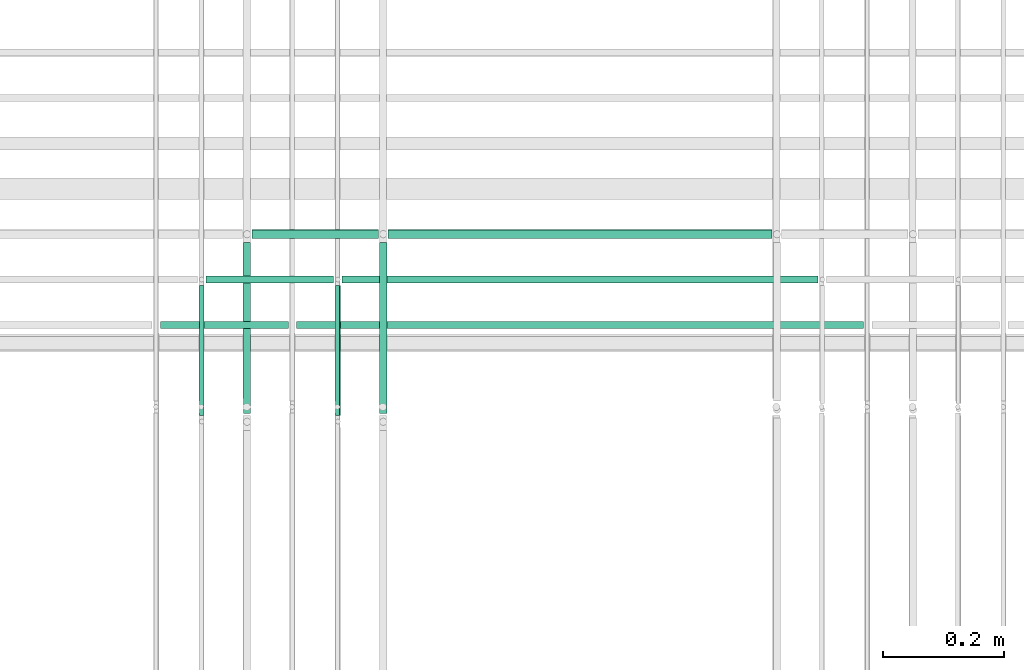
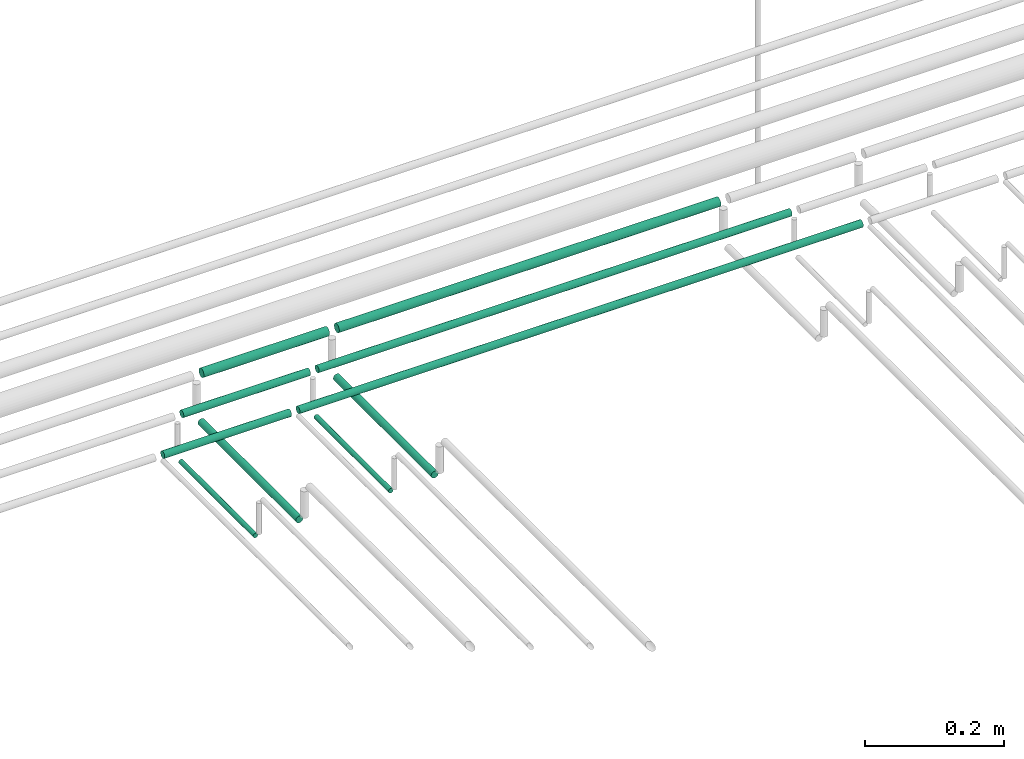
# One storey, part 198 of 331: 10 flow segments.
"""IFC2X3 building model written with IfcOpenShell, lengths in millimetres."""

from ifc_helpers import new_model, entity, si_unit, converted_unit, derived_unit, direction, frame, frame_2d, origin, origin_2d_with_axis, place, context, subcontext, project, spatial, circle, extrude, type_object, element, save


model = new_model("IFC2X3")

# Units and contexts
model_context = context("Model", 3, precision=0.01, world=origin(), true_north=direction((6.12303176911189e-17, 1.0)))
body_context = subcontext(model_context, "Body", "Model", "MODEL_VIEW")
ifc_project = project(units=[si_unit("LENGTHUNIT", "METRE", prefix="MILLI"), si_unit("AREAUNIT", "SQUARE_METRE"), si_unit("VOLUMEUNIT", "CUBIC_METRE"), converted_unit("PLANEANGLEUNIT", "DEGREE", entity("IfcRatioMeasure", 0.0174532925199433), si_unit("PLANEANGLEUNIT", "RADIAN"), dimensions=[0, 0, 0, 0, 0, 0, 0]), si_unit("MASSUNIT", "GRAM", prefix="KILO"), derived_unit("MASSDENSITYUNIT", [(si_unit("MASSUNIT", "GRAM", prefix="KILO"), 1), (si_unit("LENGTHUNIT", "METRE"), -3)]), derived_unit("MOMENTOFINERTIAUNIT", [(si_unit("LENGTHUNIT", "METRE"), 4)]), si_unit("TIMEUNIT", "SECOND"), si_unit("FREQUENCYUNIT", "HERTZ"), si_unit("THERMODYNAMICTEMPERATUREUNIT", "DEGREE_CELSIUS"), derived_unit("THERMALTRANSMITTANCEUNIT", [(si_unit("MASSUNIT", "GRAM", prefix="KILO"), 1), (si_unit("THERMODYNAMICTEMPERATUREUNIT", "KELVIN"), -1), (si_unit("TIMEUNIT", "SECOND"), -3)]), derived_unit("VOLUMETRICFLOWRATEUNIT", [(si_unit("LENGTHUNIT", "METRE"), 3), (si_unit("TIMEUNIT", "SECOND"), -1)]), derived_unit("MASSFLOWRATEUNIT", [(si_unit("MASSUNIT", "GRAM", prefix="KILO"), 1), (si_unit("TIMEUNIT", "SECOND"), -1)]), derived_unit("ROTATIONALFREQUENCYUNIT", [(si_unit("TIMEUNIT", "SECOND"), -1)]), si_unit("ELECTRICCURRENTUNIT", "AMPERE"), si_unit("ELECTRICVOLTAGEUNIT", "VOLT"), si_unit("POWERUNIT", "WATT"), si_unit("FORCEUNIT", "NEWTON", prefix="KILO"), si_unit("ILLUMINANCEUNIT", "LUX"), si_unit("LUMINOUSFLUXUNIT", "LUMEN"), si_unit("LUMINOUSINTENSITYUNIT", "CANDELA"), derived_unit("USERDEFINED", [(si_unit("MASSUNIT", "GRAM", prefix="KILO"), -1), (si_unit("LENGTHUNIT", "METRE"), -2), (si_unit("TIMEUNIT", "SECOND"), 3), (si_unit("LUMINOUSFLUXUNIT", "LUMEN"), 1)]), derived_unit("LINEARVELOCITYUNIT", [(si_unit("LENGTHUNIT", "METRE"), 1), (si_unit("TIMEUNIT", "SECOND"), -1)]), si_unit("PRESSUREUNIT", "PASCAL"), derived_unit("USERDEFINED", [(si_unit("LENGTHUNIT", "METRE"), -2), (si_unit("MASSUNIT", "GRAM", prefix="KILO"), 1), (si_unit("TIMEUNIT", "SECOND"), -2)]), derived_unit("LINEARFORCEUNIT", [(si_unit("MASSUNIT", "GRAM", prefix="KILO"), 1), (si_unit("LENGTHUNIT", "METRE"), 1), (si_unit("TIMEUNIT", "SECOND"), -2), (si_unit("LENGTHUNIT", "METRE"), -1)]), derived_unit("PLANARFORCEUNIT", [(si_unit("MASSUNIT", "GRAM", prefix="KILO"), 1), (si_unit("LENGTHUNIT", "METRE"), 1), (si_unit("TIMEUNIT", "SECOND"), -2), (si_unit("LENGTHUNIT", "METRE"), -2)])], contexts=[model_context])

# Site, building, storey
site_placement = place(None, frame((0.0, -0.00077364408347762, 0.0)))
site = spatial("IfcSite", under=ifc_project, at=site_placement, CompositionType="ELEMENT")
building_placement = place(site_placement, origin())
building = spatial("IfcBuilding", under=site, at=building_placement, CompositionType="ELEMENT")
storey_placement = place(building_placement, origin())
storey = spatial("IfcBuildingStorey", under=building, at=storey_placement, CompositionType="ELEMENT", Elevation=0.0)

# Flow segments
pipe_segment_type = type_object("IfcPipeSegmentType", PredefinedType="NOTDEFINED")
for number, where in (
    (1, (52965.0441030245, 8076.00994384932, 14469.4047277641)),
    (2, (52740.0441030245, 8076.00994384932, 14469.4047277641)),
):
    element("IfcFlowSegment", number, at=place(storey_placement, frame(where)), inside=storey, type_object=pipe_segment_type, context=body_context, shape_type="SweptSolid", body=[
        extrude(circle(Radius=4.0, at=origin_2d_with_axis()), frame((5.59527223591499, 0.0, 5.59527223591499), z_axis=(0.0, 1.0, 0.0), x_axis=(1.0, 0.0, 0.0)), (0.0, 0.0, 1.0), 214.610619978045),
    ])
flow_segment_1_placement = place(storey_placement, frame((53038.0441030245, 8079.62056382737, 14467.4047277641)))
element("IfcFlowSegment", 3, at=flow_segment_1_placement, inside=storey, type_object=pipe_segment_type, context=body_context, shape_type="SweptSolid", body=[
    extrude(circle(Radius=6.0, at=origin_2d_with_axis()), frame((7.59527223591454, 0.0, 7.5952722359167), z_axis=(0.0, 1.0, 0.0), x_axis=(1.0, 0.0, 0.0)), (0.0, 0.0, 1.0), 281.999999999984),
])
flow_segment_2_placement = place(storey_placement, frame((52813.0441030245, 8079.62056382736, 14467.4047277641)))
element("IfcFlowSegment", 4, at=flow_segment_2_placement, inside=storey, type_object=pipe_segment_type, context=body_context, shape_type="SweptSolid", body=[
    extrude(circle(Radius=6.0, at=origin_2d_with_axis()), frame((7.59527223591454, 0.0, 7.5952722359167), z_axis=(0.0, 1.0, 0.0), x_axis=(1.0, 0.0, 0.0)), (0.0, 0.0, 1.0), 282.0),
])
flow_segment_3_placement = place(storey_placement, frame((52902.6393752604, 8218.02529159143, 14542.4047277641)))
element("IfcFlowSegment", 5, at=flow_segment_3_placement, inside=storey, type_object=pipe_segment_type, context=body_context, shape_type="SweptSolid", body=[
    extrude(circle(Radius=6.0, at=frame_2d((-1.08286712929839e-12, 0.0), x_axis=(1.0, 0.0))), frame((0.0, 7.59527223591454, 7.5952722359167), z_axis=(1.0, 0.0, 0.0), x_axis=(0.0, -1.0, 0.0)), (0.0, 0.0, 1.0), 936.478228813327),
])
flow_segment_4_placement = place(storey_placement, frame((52677.6393752604, 8218.02529159143, 14542.4047277641)))
element("IfcFlowSegment", 6, at=flow_segment_4_placement, inside=storey, type_object=pipe_segment_type, context=body_context, shape_type="SweptSolid", body=[
    extrude(circle(Radius=6.0, at=frame_2d((-1.08286712929839e-12, 0.0), x_axis=(1.0, 0.0))), frame((0.0, 7.59527223591454, 7.5952722359167), z_axis=(1.0, 0.0, 0.0), x_axis=(0.0, -1.0, 0.0)), (0.0, 0.0, 1.0), 211.000000000004),
])
flow_segment_5_placement = place(storey_placement, frame((52977.6373797676, 8293.02529159145, 14542.5765068697)))
element("IfcFlowSegment", 7, at=flow_segment_5_placement, inside=storey, type_object=pipe_segment_type, context=body_context, shape_type="SweptSolid", body=[
    extrude(circle(Radius=6.0, at=origin_2d_with_axis()), frame((0.000126456651605622, 7.59527223591562, 7.59527223458261), z_axis=(1.0, 0.0, 2.10761091446843e-05), x_axis=(0.0, -1.0, 0.0)), (0.0, 0.0, 1.0), 786.478228626369),
])
flow_segment_6_placement = place(storey_placement, frame((52752.6373798686, 8293.02529159145, 14542.5717647451)))
element("IfcFlowSegment", 8, at=flow_segment_6_placement, inside=storey, type_object=pipe_segment_type, context=body_context, shape_type="SweptSolid", body=[
    extrude(circle(Radius=6.0, at=frame_2d((0.0, -2.16573425811577e-12), x_axis=(1.0, 0.0))), frame((0.000126456651605622, 7.59527223591562, 7.59527223458044), z_axis=(1.0, 0.0, 2.10761091739803e-05), x_axis=(0.0, -1.0, 0.0)), (0.0, 0.0, 1.0), 210.999999949002),
])
flow_segment_7_placement = place(storey_placement, frame((53053.6373208695, 8366.52529159144, 14541.0911641396)))
element("IfcFlowSegment", 9, at=flow_segment_7_placement, inside=storey, type_object=pipe_segment_type, context=body_context, shape_type="SweptSolid", body=[
    extrude(circle(Radius=7.5, at=origin_2d_with_axis()), frame((0.000168554696574574, 9.09527223591636, 9.09527223402134), z_axis=(1.0, 0.0, 2.24739589767322e-05), x_axis=(0.0, -1.0, 0.0)), (0.0, 0.0, 1.0), 634.478228944128),
])
flow_segment_8_placement = place(storey_placement, frame((52828.637320985, 8366.52529159144, 14541.0861074988)))
element("IfcFlowSegment", 10, at=flow_segment_8_placement, inside=storey, type_object=pipe_segment_type, context=body_context, shape_type="SweptSolid", body=[
    extrude(circle(Radius=7.5, at=origin_2d_with_axis()), frame((0.000168554696574574, 9.09527223591636, 9.09527223401918), z_axis=(1.0, 0.0, 2.24739590045187e-05), x_axis=(0.0, -1.0, 0.0)), (0.0, 0.0, 1.0), 209.000000301964),
])

save(model, "model.ifc")
